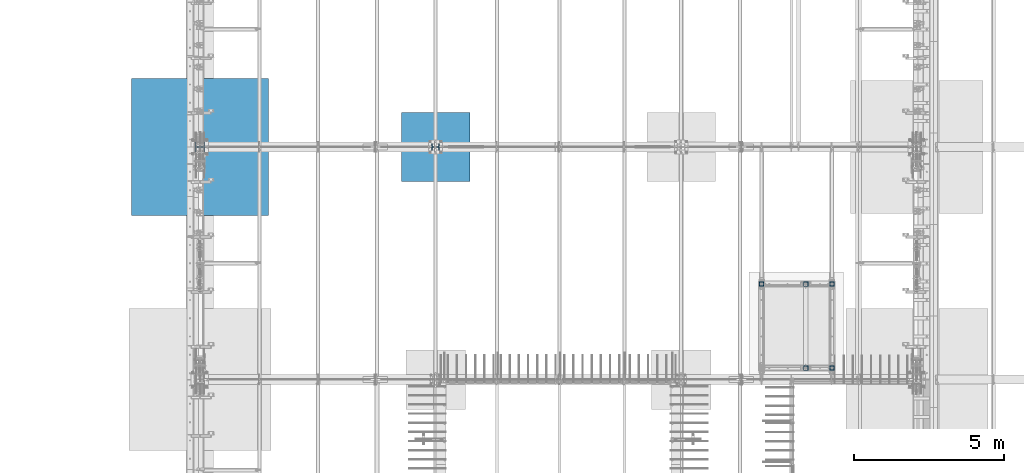
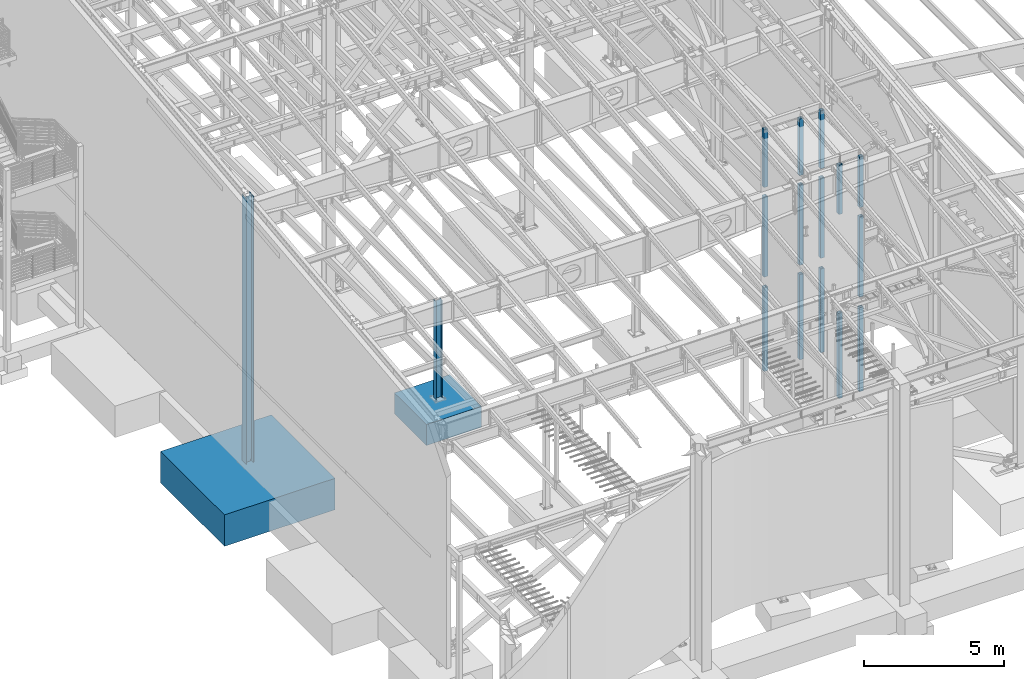
# One storey, part 356 of 1179: 18 columns, 18 elements without a shape of their own.
"""IFC2X3 building model written with IfcOpenShell, lengths in millimetres."""

from ifc_helpers import new_model, si_unit, frame, origin_with_axes, place, context, subcontext, project, spatial, faceted_brep, material, type_object, element, aggregate, save


model = new_model("IFC2X3")

# Units and contexts
model_context = context("Model", 3, precision=1e-05, world=origin_with_axes())
body_context = subcontext(model_context, "Body", "Model", "MODEL_VIEW")
ifc_project = project(units=[si_unit("LENGTHUNIT", "METRE", prefix="MILLI"), si_unit("AREAUNIT", "SQUARE_METRE"), si_unit("VOLUMEUNIT", "CUBIC_METRE"), si_unit("MASSUNIT", "GRAM", prefix="KILO"), si_unit("TIMEUNIT", "SECOND"), si_unit("PLANEANGLEUNIT", "RADIAN"), si_unit("SOLIDANGLEUNIT", "STERADIAN"), si_unit("THERMODYNAMICTEMPERATUREUNIT", "DEGREE_CELSIUS"), si_unit("LUMINOUSINTENSITYUNIT", "LUMEN")], contexts=[model_context])

# Site, building, storey
site_placement = place(None, origin_with_axes())
site = spatial("IfcSite", under=ifc_project, at=site_placement, CompositionType="ELEMENT")
building_placement = place(site_placement, origin_with_axes())
building = spatial("IfcBuilding", under=site, at=building_placement, Name="Undefined", CompositionType="ELEMENT")
storey_placement = place(building_placement, origin_with_axes())
storey = spatial("IfcBuildingStorey", under=building, at=storey_placement, Name="Undefined", CompositionType="ELEMENT", Elevation=0.0)

# Assembly, column
assembly_1_placement = place(storey_placement, origin_with_axes())
assembly_1 = element("IfcElementAssembly", 1, at=assembly_1_placement, inside=storey, Name="COLUMN", AssemblyPlace="NOTDEFINED", PredefinedType="RIGID_FRAME")
ifc_material_1 = material()
column_type_1 = type_object("IfcColumnType", Name="HSS6X6X3/8", PredefinedType="NOTDEFINED")
column_1_placement = place(assembly_1_placement, frame((21475.7, 11868.15, 4102.1), z_axis=(0.0, 1.0, 0.0), x_axis=(0.0, 0.0, 1.0)))
column_1 = element("IfcColumn", 2, at=column_1_placement, type_object=column_type_1, material=ifc_material_1, Name="COLUMN", ObjectType="HSS6X6X3/8", context=body_context, shape_type="Brep", body=[
    faceted_brep([(19.0500000000002, 66.6749999999993, -66.6749999999993), (19.0500000000002, -66.6749999999993, -66.6749999999993), (3524.25, -66.6749999999993, -66.6749999999993), (3524.25, 66.6749999999993, -66.6749999999993), (19.0500000000002, -66.6749999999993, 66.6749999999993), (3524.25, -66.6749999999993, 66.6749999999993), (19.0500000000002, 66.6749999999993, 66.6749999999993), (3524.25, 66.6749999999993, 66.6749999999993), (19.0500000000002, 76.2000000000007, -76.2000000000007), (19.0500000000002, 76.2000000000007, 76.2000000000007), (3524.25, 76.2000000000007, 76.2000000000007), (3524.25, 76.2000000000007, -76.2000000000007), (19.0500000000002, -76.2000000000007, 76.2000000000007), (3524.25, -76.2000000000007, 76.2000000000007), (19.0500000000002, -76.2000000000007, -76.2000000000007), (3524.25, -76.2000000000007, -76.2000000000007)], [[[0, 1, 2, 3]], [[1, 4, 5, 2]], [[4, 6, 7, 5]], [[6, 0, 3, 7]], [[8, 9, 10, 11]], [[9, 12, 13, 10]], [[12, 14, 15, 13]], [[14, 8, 11, 15]], [[13, 15, 11, 10], [5, 7, 3, 2]], [[14, 12, 9, 8], [6, 4, 1, 0]]]),
])
aggregate(assembly_1, [column_1])

assembly_2_placement = place(storey_placement, origin_with_axes())
assembly_2 = element("IfcElementAssembly", 3, at=assembly_2_placement, inside=storey, Name="COLUMN", AssemblyPlace="NOTDEFINED", PredefinedType="RIGID_FRAME")
column_2_placement = place(assembly_2_placement, frame((19138.9, 14662.15, 4102.1), z_axis=(0.0, 1.0, 0.0), x_axis=(0.0, 0.0, 1.0)))
column_2 = element("IfcColumn", 4, at=column_2_placement, type_object=column_type_1, material=ifc_material_1, Name="COLUMN", ObjectType="HSS6X6X3/8", context=body_context, shape_type="Brep", body=[
    faceted_brep([(19.0500000000002, 66.6749999999993, -66.6749999999993), (19.0500000000002, -66.6749999999993, -66.6749999999993), (3524.25, -66.6749999999993, -66.6749999999993), (3524.25, 66.6749999999993, -66.6749999999993), (19.0500000000002, -66.6749999999993, 66.6749999999993), (3524.25, -66.6749999999993, 66.6749999999993), (19.0500000000002, 66.6749999999993, 66.6749999999993), (3524.25, 66.6749999999993, 66.6749999999993), (19.0500000000002, 76.2000000000007, -76.2000000000007), (19.0500000000002, 76.2000000000007, 76.2000000000007), (3524.25, 76.2000000000007, 76.2000000000007), (3524.25, 76.2000000000007, -76.2000000000007), (19.0500000000002, -76.2000000000007, 76.2000000000007), (3524.25, -76.2000000000007, 76.2000000000007), (19.0500000000002, -76.2000000000007, -76.2000000000007), (3524.25, -76.2000000000007, -76.2000000000007)], [[[0, 1, 2, 3]], [[1, 4, 5, 2]], [[4, 6, 7, 5]], [[6, 0, 3, 7]], [[8, 9, 10, 11]], [[9, 12, 13, 10]], [[12, 14, 15, 13]], [[14, 8, 11, 15]], [[13, 15, 11, 10], [5, 7, 3, 2]], [[14, 12, 9, 8], [6, 4, 1, 0]]]),
])
aggregate(assembly_2, [column_2])

assembly_3_placement = place(storey_placement, origin_with_axes())
assembly_3 = element("IfcElementAssembly", 5, at=assembly_3_placement, inside=storey, Name="COLUMN", AssemblyPlace="NOTDEFINED", PredefinedType="RIGID_FRAME")
column_3_placement = place(assembly_3_placement, frame((21475.7, 14662.15, 4102.1), z_axis=(0.0, 1.0, 0.0), x_axis=(0.0, 0.0, 1.0)))
column_3 = element("IfcColumn", 6, at=column_3_placement, type_object=column_type_1, material=ifc_material_1, Name="COLUMN", ObjectType="HSS6X6X3/8", context=body_context, shape_type="Brep", body=[
    faceted_brep([(19.0500000000002, 66.6749999999993, -66.6749999999993), (19.0500000000002, -66.6749999999993, -66.6749999999993), (3524.25, -66.6749999999993, -66.6749999999993), (3524.25, 66.6749999999993, -66.6749999999993), (19.0500000000002, -66.6749999999993, 66.6749999999993), (3524.25, -66.6749999999993, 66.6749999999993), (19.0500000000002, 66.6749999999993, 66.6749999999993), (3524.25, 66.6749999999993, 66.6749999999993), (19.0500000000002, 76.2000000000007, -76.2000000000007), (19.0500000000002, 76.2000000000007, 76.2000000000007), (3524.25, 76.2000000000007, 76.2000000000007), (3524.25, 76.2000000000007, -76.2000000000007), (19.0500000000002, -76.2000000000007, 76.2000000000007), (3524.25, -76.2000000000007, 76.2000000000007), (19.0500000000002, -76.2000000000007, -76.2000000000007), (3524.25, -76.2000000000007, -76.2000000000007)], [[[0, 1, 2, 3]], [[1, 4, 5, 2]], [[4, 6, 7, 5]], [[6, 0, 3, 7]], [[8, 9, 10, 11]], [[9, 12, 13, 10]], [[12, 14, 15, 13]], [[14, 8, 11, 15]], [[13, 15, 11, 10], [5, 7, 3, 2]], [[14, 12, 9, 8], [6, 4, 1, 0]]]),
])
aggregate(assembly_3, [column_3])

assembly_4_placement = place(storey_placement, origin_with_axes())
assembly_4 = element("IfcElementAssembly", 7, at=assembly_4_placement, inside=storey, Name="COLUMN", AssemblyPlace="NOTDEFINED", PredefinedType="RIGID_FRAME")
column_4_placement = place(assembly_4_placement, frame((20612.1, 14662.15, 4102.1), z_axis=(0.0, 1.0, 0.0), x_axis=(0.0, 0.0, 1.0)))
column_4 = element("IfcColumn", 8, at=column_4_placement, type_object=column_type_1, material=ifc_material_1, Name="COLUMN", ObjectType="HSS6X6X3/8", context=body_context, shape_type="Brep", body=[
    faceted_brep([(19.0500000000002, 66.6749999999993, -66.6749999999993), (19.0500000000002, -66.6749999999993, -66.6749999999993), (3524.25, -66.6749999999993, -66.6749999999993), (3524.25, 66.6749999999993, -66.6749999999993), (19.0500000000002, -66.6749999999993, 66.6749999999993), (3524.25, -66.6749999999993, 66.6749999999993), (19.0500000000002, 66.6749999999993, 66.6749999999993), (3524.25, 66.6749999999993, 66.6749999999993), (19.0500000000002, 76.2000000000007, -76.2000000000007), (19.0500000000002, 76.2000000000007, 76.2000000000007), (3524.25, 76.2000000000007, 76.2000000000007), (3524.25, 76.2000000000007, -76.2000000000007), (19.0500000000002, -76.2000000000007, 76.2000000000007), (3524.25, -76.2000000000007, 76.2000000000007), (19.0500000000002, -76.2000000000007, -76.2000000000007), (3524.25, -76.2000000000007, -76.2000000000007)], [[[0, 1, 2, 3]], [[1, 4, 5, 2]], [[4, 6, 7, 5]], [[6, 0, 3, 7]], [[8, 9, 10, 11]], [[9, 12, 13, 10]], [[12, 14, 15, 13]], [[14, 8, 11, 15]], [[13, 15, 11, 10], [5, 7, 3, 2]], [[14, 12, 9, 8], [6, 4, 1, 0]]]),
])
aggregate(assembly_4, [column_4])

assembly_5_placement = place(storey_placement, origin_with_axes())
assembly_5 = element("IfcElementAssembly", 9, at=assembly_5_placement, inside=storey, Name="COLUMN", AssemblyPlace="NOTDEFINED", PredefinedType="RIGID_FRAME")
column_5_placement = place(assembly_5_placement, frame((21475.7, 11868.15, 8013.7), z_axis=(0.0, 1.0, 0.0), x_axis=(0.0, 0.0, 1.0)))
column_5 = element("IfcColumn", 10, at=column_5_placement, type_object=column_type_1, material=ifc_material_1, Name="COLUMN", ObjectType="HSS6X6X3/8", context=body_context, shape_type="Brep", body=[
    faceted_brep([(19.0500000000002, 66.6749999999993, -66.6749999999993), (19.0500000000002, -66.6749999999993, -66.6749999999993), (2231.40740840967, -66.6749999999993, -66.6749999999993), (2231.40740840967, 66.6749999999993, -66.6749999999993), (19.0500000000002, -66.6749999999993, 66.6749999999993), (2231.40740840967, -66.6749999999993, 66.6749999999993), (19.0500000000002, 66.6749999999993, 66.6749999999993), (2231.40740840967, 66.6749999999993, 66.6749999999993), (19.0500000000002, 76.2000000000007, -76.2000000000007), (19.0500000000002, 76.2000000000007, 76.2000000000007), (2231.40740840967, 76.2000000000007, 76.2000000000007), (2231.40740840967, 76.2000000000007, -76.2000000000007), (19.0500000000002, -76.2000000000007, 76.2000000000007), (2231.40740840967, -76.2000000000007, 76.2000000000007), (19.0500000000002, -76.2000000000007, -76.2000000000007), (2231.40740840967, -76.2000000000007, -76.2000000000007)], [[[0, 1, 2, 3]], [[1, 4, 5, 2]], [[4, 6, 7, 5]], [[6, 0, 3, 7]], [[8, 9, 10, 11]], [[9, 12, 13, 10]], [[12, 14, 15, 13]], [[14, 8, 11, 15]], [[13, 15, 11, 10], [5, 7, 3, 2]], [[14, 12, 9, 8], [6, 4, 1, 0]]]),
])
aggregate(assembly_5, [column_5])

assembly_6_placement = place(storey_placement, origin_with_axes())
assembly_6 = element("IfcElementAssembly", 11, at=assembly_6_placement, inside=storey, Name="COLUMN", AssemblyPlace="NOTDEFINED", PredefinedType="RIGID_FRAME")
column_6_placement = place(assembly_6_placement, frame((20612.1, 11868.15, 8013.7), z_axis=(0.0, 1.0, 0.0), x_axis=(0.0, 0.0, 1.0)))
column_6 = element("IfcColumn", 12, at=column_6_placement, type_object=column_type_1, material=ifc_material_1, Name="COLUMN", ObjectType="HSS6X6X3/8", context=body_context, shape_type="Brep", body=[
    faceted_brep([(19.0500000000002, 66.6749999999993, -66.6749999999993), (19.0500000000002, -66.6749999999993, -66.6749999999993), (2179.835937, -66.6749999999993, -66.6749999999993), (2179.835937, 66.6749999999993, -66.6749999999993), (19.0500000000002, -66.6749999999993, 66.6749999999993), (2179.835937, -66.6749999999993, 66.6749999999993), (19.0500000000002, 66.6749999999993, 66.6749999999993), (2179.835937, 66.6749999999993, 66.6749999999993), (19.0500000000002, 76.2000000000007, -76.2000000000007), (19.0500000000002, 76.2000000000007, 76.2000000000007), (2179.835937, 76.2000000000007, 76.2000000000007), (2179.835937, 76.2000000000007, -76.2000000000007), (19.0500000000002, -76.2000000000007, 76.2000000000007), (2179.835937, -76.2000000000007, 76.2000000000007), (19.0500000000002, -76.2000000000007, -76.2000000000007), (2179.835937, -76.2000000000007, -76.2000000000007)], [[[0, 1, 2, 3]], [[1, 4, 5, 2]], [[4, 6, 7, 5]], [[6, 0, 3, 7]], [[8, 9, 10, 11]], [[9, 12, 13, 10]], [[12, 14, 15, 13]], [[14, 8, 11, 15]], [[13, 15, 11, 10], [5, 7, 3, 2]], [[14, 12, 9, 8], [6, 4, 1, 0]]]),
])
aggregate(assembly_6, [column_6])

assembly_7_placement = place(storey_placement, origin_with_axes())
assembly_7 = element("IfcElementAssembly", 13, at=assembly_7_placement, inside=storey, Name="COLUMN", AssemblyPlace="NOTDEFINED", PredefinedType="RIGID_FRAME")
column_7_placement = place(assembly_7_placement, frame((21475.7, 14662.15, 8013.7), z_axis=(0.0, 1.0, 0.0), x_axis=(0.0, 0.0, 1.0)))
column_7 = element("IfcColumn", 14, at=column_7_placement, type_object=column_type_1, material=ifc_material_1, Name="COLUMN", ObjectType="HSS6X6X3/8", context=body_context, shape_type="Brep", body=[
    faceted_brep([(19.0500000000002, 66.6749999999993, -66.6749999999993), (19.0500000000002, -66.6749999999993, -66.6749999999993), (2547.12147140967, -66.6749999999993, -66.6749999999993), (2547.12147140967, 66.6749999999993, -66.6749999999993), (19.0500000000002, -66.6749999999993, 66.6749999999993), (2547.12147140967, -66.6749999999993, 66.6749999999993), (19.0500000000002, 66.6749999999993, 66.6749999999993), (2547.12147140967, 66.6749999999993, 66.6749999999993), (19.0500000000002, 76.2000000000007, -76.2000000000007), (19.0500000000002, 76.2000000000007, 76.2000000000007), (2547.12147140967, 76.2000000000007, 76.2000000000007), (2547.12147140967, 76.2000000000007, -76.2000000000007), (19.0500000000002, -76.2000000000007, 76.2000000000007), (2547.12147140967, -76.2000000000007, 76.2000000000007), (19.0500000000002, -76.2000000000007, -76.2000000000007), (2547.12147140967, -76.2000000000007, -76.2000000000007)], [[[0, 1, 2, 3]], [[1, 4, 5, 2]], [[4, 6, 7, 5]], [[6, 0, 3, 7]], [[8, 9, 10, 11]], [[9, 12, 13, 10]], [[12, 14, 15, 13]], [[14, 8, 11, 15]], [[13, 15, 11, 10], [5, 7, 3, 2]], [[14, 12, 9, 8], [6, 4, 1, 0]]]),
])
aggregate(assembly_7, [column_7])

assembly_8_placement = place(storey_placement, origin_with_axes())
assembly_8 = element("IfcElementAssembly", 15, at=assembly_8_placement, inside=storey, Name="COLUMN", AssemblyPlace="NOTDEFINED", PredefinedType="RIGID_FRAME")
column_8_placement = place(assembly_8_placement, frame((20612.1, 14662.15, 8013.7), z_axis=(0.0, 1.0, 0.0), x_axis=(0.0, 0.0, 1.0)))
column_8 = element("IfcColumn", 16, at=column_8_placement, type_object=column_type_1, material=ifc_material_1, Name="COLUMN", ObjectType="HSS6X6X3/8", context=body_context, shape_type="Brep", body=[
    faceted_brep([(19.0500000000002, 66.6749999999993, -66.6749999999993), (19.0500000000002, -66.6749999999993, -66.6749999999993), (2495.45821831457, -66.6749999999993, -66.6749999999993), (2495.45821831457, 66.6749999999993, -66.6749999999993), (19.0500000000002, -66.6749999999993, 66.6749999999993), (2495.45821831457, -66.6749999999993, 66.6749999999993), (19.0500000000002, 66.6749999999993, 66.6749999999993), (2495.45821831457, 66.6749999999993, 66.6749999999993), (19.0500000000002, 76.2000000000007, -76.2000000000007), (19.0500000000002, 76.2000000000007, 76.2000000000007), (2495.45821831457, 76.2000000000007, 76.2000000000007), (2495.45821831457, 76.2000000000007, -76.2000000000007), (19.0500000000002, -76.2000000000007, 76.2000000000007), (2495.45821831457, -76.2000000000007, 76.2000000000007), (19.0500000000002, -76.2000000000007, -76.2000000000007), (2495.45821831457, -76.2000000000007, -76.2000000000007)], [[[0, 1, 2, 3]], [[1, 4, 5, 2]], [[4, 6, 7, 5]], [[6, 0, 3, 7]], [[8, 9, 10, 11]], [[9, 12, 13, 10]], [[12, 14, 15, 13]], [[14, 8, 11, 15]], [[13, 15, 11, 10], [5, 7, 3, 2]], [[14, 12, 9, 8], [6, 4, 1, 0]]]),
])
aggregate(assembly_8, [column_8])

assembly_9_placement = place(storey_placement, origin_with_axes())
assembly_9 = element("IfcElementAssembly", 17, at=assembly_9_placement, inside=storey, Name="COLUMN", AssemblyPlace="NOTDEFINED", PredefinedType="RIGID_FRAME")
column_9_placement = place(assembly_9_placement, frame((19138.9, 14662.15, 8013.7), z_axis=(0.0, 1.0, 0.0), x_axis=(0.0, 0.0, 1.0)))
column_9 = element("IfcColumn", 18, at=column_9_placement, type_object=column_type_1, material=ifc_material_1, Name="COLUMN", ObjectType="HSS6X6X3/8", context=body_context, shape_type="Brep", body=[
    faceted_brep([(19.0500000000002, 66.6749999999993, -66.6749999999993), (19.0500000000002, -66.6749999999993, -66.6749999999993), (2547.12147140967, -66.6749999999993, -66.6749999999993), (2547.12147140967, 66.6749999999993, -66.6749999999993), (19.0500000000002, -66.6749999999993, 66.6749999999993), (2547.12147140967, -66.6749999999993, 66.6749999999993), (19.0500000000002, 66.6749999999993, 66.6749999999993), (2547.12147140967, 66.6749999999993, 66.6749999999993), (19.0500000000002, 76.2000000000007, -76.2000000000007), (19.0500000000002, 76.2000000000007, 76.2000000000007), (2547.12147140967, 76.2000000000007, 76.2000000000007), (2547.12147140967, 76.2000000000007, -76.2000000000007), (19.0500000000002, -76.2000000000007, 76.2000000000007), (2547.12147140967, -76.2000000000007, 76.2000000000007), (19.0500000000002, -76.2000000000007, -76.2000000000007), (2547.12147140967, -76.2000000000007, -76.2000000000007)], [[[0, 1, 2, 3]], [[1, 4, 5, 2]], [[4, 6, 7, 5]], [[6, 0, 3, 7]], [[8, 9, 10, 11]], [[9, 12, 13, 10]], [[12, 14, 15, 13]], [[14, 8, 11, 15]], [[13, 15, 11, 10], [5, 7, 3, 2]], [[14, 12, 9, 8], [6, 4, 1, 0]]]),
])
aggregate(assembly_9, [column_9])

assembly_10_placement = place(storey_placement, origin_with_axes())
assembly_10 = element("IfcElementAssembly", 19, at=assembly_10_placement, inside=storey, Name="COLUMN", AssemblyPlace="NOTDEFINED", PredefinedType="RIGID_FRAME")
column_10_placement = place(assembly_10_placement, frame((20612.1, 14662.15, 0.0), z_axis=(0.0, 1.0, 0.0), x_axis=(0.0, 0.0, 1.0)))
column_10 = element("IfcColumn", 20, at=column_10_placement, type_object=column_type_1, material=ifc_material_1, Name="COLUMN", ObjectType="HSS6X6X3/8", context=body_context, shape_type="Brep", body=[
    faceted_brep([(0.0, 66.6749999999993, -66.6750000000029), (0.0, -66.6749999999993, -66.6750000000029), (3714.75000000008, -66.6749999999993, -66.6749999999993), (3714.75000000008, 66.6749999999993, -66.6749999999993), (0.0, -66.6749999999993, 66.6750000000029), (3714.75000000008, -66.6749999999993, 66.6749999999993), (0.0, 66.6749999999993, 66.6750000000029), (3714.75000000008, 66.6749999999993, 66.6749999999993), (6.54836185276508e-11, 76.2, -76.1999999999998), (6.54836185276508e-11, 76.2, 76.1999999999998), (3714.75000000008, 76.2000000000007, 76.2000000000007), (3714.75000000008, 76.2000000000007, -76.2000000000007), (-6.54836185276508e-11, -76.2, 76.1999999999998), (3714.75000000008, -76.2000000000007, 76.2000000000007), (-6.54836185276508e-11, -76.2, -76.1999999999998), (3714.75000000008, -76.2000000000007, -76.2000000000007)], [[[0, 1, 2, 3]], [[1, 4, 5, 2]], [[4, 6, 7, 5]], [[6, 0, 3, 7]], [[8, 9, 10, 11]], [[9, 12, 13, 10]], [[12, 14, 15, 13]], [[14, 8, 11, 15]], [[13, 15, 11, 10], [5, 7, 3, 2]], [[14, 12, 9, 8], [6, 4, 1, 0]]]),
])
aggregate(assembly_10, [column_10])

assembly_11_placement = place(storey_placement, origin_with_axes())
assembly_11 = element("IfcElementAssembly", 21, at=assembly_11_placement, inside=storey, Name="COLUMN", AssemblyPlace="NOTDEFINED", PredefinedType="RIGID_FRAME")
column_11_placement = place(assembly_11_placement, frame((20612.1, 11868.15, 0.0), z_axis=(0.0, 1.0, 0.0), x_axis=(0.0, 0.0, 1.0)))
column_11 = element("IfcColumn", 22, at=column_11_placement, type_object=column_type_1, material=ifc_material_1, Name="COLUMN", ObjectType="HSS6X6X3/8", context=body_context, shape_type="Brep", body=[
    faceted_brep([(0.0, 66.6749999999993, -66.6750000000029), (0.0, -66.6749999999993, -66.6750000000029), (3714.75000000008, -66.6749999999993, -66.6749999999993), (3714.75000000008, 66.6749999999993, -66.6749999999993), (0.0, -66.6749999999993, 66.6750000000029), (3714.75000000008, -66.6749999999993, 66.6749999999993), (0.0, 66.6749999999993, 66.6750000000029), (3714.75000000008, 66.6749999999993, 66.6749999999993), (6.54836185276508e-11, 76.2, -76.1999999999998), (6.54836185276508e-11, 76.2, 76.1999999999998), (3714.75000000008, 76.2000000000007, 76.2000000000007), (3714.75000000008, 76.2000000000007, -76.2000000000007), (-6.54836185276508e-11, -76.2, 76.1999999999998), (3714.75000000008, -76.2000000000007, 76.2000000000007), (-6.54836185276508e-11, -76.2, -76.1999999999998), (3714.75000000008, -76.2000000000007, -76.2000000000007)], [[[0, 1, 2, 3]], [[1, 4, 5, 2]], [[4, 6, 7, 5]], [[6, 0, 3, 7]], [[8, 9, 10, 11]], [[9, 12, 13, 10]], [[12, 14, 15, 13]], [[14, 8, 11, 15]], [[13, 15, 11, 10], [5, 7, 3, 2]], [[14, 12, 9, 8], [6, 4, 1, 0]]]),
])
aggregate(assembly_11, [column_11])

assembly_12_placement = place(storey_placement, origin_with_axes())
assembly_12 = element("IfcElementAssembly", 23, at=assembly_12_placement, inside=storey, Name="COLUMN", AssemblyPlace="NOTDEFINED", PredefinedType="RIGID_FRAME")
column_type_2 = type_object("IfcColumnType", Name="HSS6X6X5/8", PredefinedType="NOTDEFINED")
column_12_placement = place(assembly_12_placement, frame((19138.8967731331, 14662.1500000111, -4.59294824395329e-11), z_axis=(0.0, 1.0, 0.0), x_axis=(0.0, 0.0, 1.0)))
column_12 = element("IfcColumn", 24, at=column_12_placement, type_object=column_type_2, material=ifc_material_1, Name="COLUMN", ObjectType="HSS6X6X5/8", context=body_context, shape_type="Brep", body=[
    faceted_brep([(0.0, 60.3250000000007, -60.3250000000007), (2.71050543121376e-20, -60.3250000000007, -60.3250000000007), (3660.775, -60.325000001314, -60.3250000000007), (3660.775, 60.3249999986838, -60.3250000000007), (2.71050543121376e-20, -60.3250000000007, 60.3250000000007), (3660.775, -60.325000001314, 60.3250000000007), (0.0, 60.3250000000007, 60.3250000000007), (3660.775, 60.3249999986838, 60.3250000000007), (6.54836185276508e-11, 76.2, -76.1999999999998), (6.54836185276508e-11, 76.2, 76.1999999999998), (3660.775, 76.1999999986838, 76.2000000000007), (3660.775, 76.1999999986838, -76.2000000000007), (-6.54836185276508e-11, -76.2, 76.1999999999998), (3660.775, -76.200000001314, 76.2000000000007), (-6.54836185276508e-11, -76.2, -76.1999999999998), (3660.775, -76.200000001314, -76.2000000000007)], [[[0, 1, 2, 3]], [[1, 4, 5, 2]], [[4, 6, 7, 5]], [[6, 0, 3, 7]], [[8, 9, 10, 11]], [[9, 12, 13, 10]], [[12, 14, 15, 13]], [[14, 8, 11, 15]], [[13, 15, 11, 10], [5, 7, 3, 2]], [[14, 12, 9, 8], [6, 4, 1, 0]]]),
])
aggregate(assembly_12, [column_12])

assembly_13_placement = place(storey_placement, origin_with_axes())
assembly_13 = element("IfcElementAssembly", 25, at=assembly_13_placement, inside=storey, Name="COLUMN", AssemblyPlace="NOTDEFINED", PredefinedType="RIGID_FRAME")
column_13_placement = place(assembly_13_placement, frame((21475.7, 14662.15, 0.0), z_axis=(0.0, 1.0, 0.0), x_axis=(0.0, 0.0, 1.0)))
column_13 = element("IfcColumn", 26, at=column_13_placement, type_object=column_type_2, material=ifc_material_1, Name="COLUMN", ObjectType="HSS6X6X5/8", context=body_context, shape_type="Brep", body=[
    faceted_brep([(0.0, 60.3250000000007, -60.3250000000007), (2.71050543121376e-20, -60.3250000000007, -60.3250000000007), (3660.775, -60.325000001314, -60.3250000000007), (3660.775, 60.3249999986838, -60.3250000000007), (2.71050543121376e-20, -60.3250000000007, 60.3250000000007), (3660.775, -60.325000001314, 60.3250000000007), (0.0, 60.3250000000007, 60.3250000000007), (3660.775, 60.3249999986838, 60.3250000000007), (6.54836185276508e-11, 76.2, -76.1999999999998), (6.54836185276508e-11, 76.2, 76.1999999999998), (3660.775, 76.1999999986838, 76.2000000000007), (3660.775, 76.1999999986838, -76.2000000000007), (-6.54836185276508e-11, -76.2, 76.1999999999998), (3660.775, -76.200000001314, 76.2000000000007), (-6.54836185276508e-11, -76.2, -76.1999999999998), (3660.775, -76.200000001314, -76.2000000000007)], [[[0, 1, 2, 3]], [[1, 4, 5, 2]], [[4, 6, 7, 5]], [[6, 0, 3, 7]], [[8, 9, 10, 11]], [[9, 12, 13, 10]], [[12, 14, 15, 13]], [[14, 8, 11, 15]], [[13, 15, 11, 10], [5, 7, 3, 2]], [[14, 12, 9, 8], [6, 4, 1, 0]]]),
])
aggregate(assembly_13, [column_13])

assembly_14_placement = place(storey_placement, origin_with_axes())
assembly_14 = element("IfcElementAssembly", 27, at=assembly_14_placement, inside=storey, Name="COLUMN", AssemblyPlace="NOTDEFINED", PredefinedType="RIGID_FRAME")
column_14_placement = place(assembly_14_placement, frame((21475.7, 11868.15, 0.0), z_axis=(0.0, 1.0, 0.0), x_axis=(0.0, 0.0, 1.0)))
column_14 = element("IfcColumn", 28, at=column_14_placement, type_object=column_type_2, material=ifc_material_1, Name="COLUMN", ObjectType="HSS6X6X5/8", context=body_context, shape_type="Brep", body=[
    faceted_brep([(0.0, 60.3250000000007, -60.3250000000007), (2.71050543121376e-20, -60.3250000000007, -60.3250000000007), (3660.775, -60.325000001314, -60.3250000000007), (3660.775, 60.3249999986838, -60.3250000000007), (2.71050543121376e-20, -60.3250000000007, 60.3250000000007), (3660.775, -60.325000001314, 60.3250000000007), (0.0, 60.3250000000007, 60.3250000000007), (3660.775, 60.3249999986838, 60.3250000000007), (6.54836185276508e-11, 76.2, -76.1999999999998), (6.54836185276508e-11, 76.2, 76.1999999999998), (3660.775, 76.1999999986838, 76.2000000000007), (3660.775, 76.1999999986838, -76.2000000000007), (-6.54836185276508e-11, -76.2, 76.1999999999998), (3660.775, -76.200000001314, 76.2000000000007), (-6.54836185276508e-11, -76.2, -76.1999999999998), (3660.775, -76.200000001314, -76.2000000000007)], [[[0, 1, 2, 3]], [[1, 4, 5, 2]], [[4, 6, 7, 5]], [[6, 0, 3, 7]], [[8, 9, 10, 11]], [[9, 12, 13, 10]], [[12, 14, 15, 13]], [[14, 8, 11, 15]], [[13, 15, 11, 10], [5, 7, 3, 2]], [[14, 12, 9, 8], [6, 4, 1, 0]]]),
])
aggregate(assembly_14, [column_14])

assembly_15_placement = place(storey_placement, origin_with_axes())
assembly_15 = element("IfcElementAssembly", 29, at=assembly_15_placement, inside=storey, Name="FOOTING", AssemblyPlace="NOTDEFINED", PredefinedType="REINFORCEMENT_UNIT")
ifc_material_2 = material(Name="CONCRETE/3000")
column_type_3 = type_object("IfcColumnType", PredefinedType="NOTDEFINED")
column_15_placement = place(assembly_15_placement, frame((8280.4, 19227.8, -1168.4), z_axis=(-1.0, 0.0, 0.0), x_axis=(0.0, 0.0, 1.0)))
column_15 = element("IfcColumn", 30, at=column_15_placement, type_object=column_type_3, material=ifc_material_2, Name="FOOTING", context=body_context, shape_type="Brep", body=[
    faceted_brep([(0.0, 1143.0, -1143.0), (0.0, 1143.0, 1143.0), (914.4, 1143.0, 1143.0), (914.4, 1143.0, -1143.0), (0.0, -1143.0, 1143.0), (914.4, -1143.0, 1143.0), (0.0, -1143.0, -1143.0), (914.4, -1143.0, -1143.0)], [[[0, 1, 2, 3]], [[1, 4, 5, 2]], [[4, 6, 7, 5]], [[6, 0, 3, 7]], [[5, 7, 3, 2]], [[6, 4, 1, 0]]]),
])
aggregate(assembly_15, [column_15])

assembly_16_placement = place(storey_placement, origin_with_axes())
assembly_16 = element("IfcElementAssembly", 31, at=assembly_16_placement, inside=storey, Name="FOOTING", AssemblyPlace="NOTDEFINED", PredefinedType="REINFORCEMENT_UNIT")
column_type_4 = type_object("IfcColumnType", PredefinedType="NOTDEFINED")
column_16_placement = place(assembly_16_placement, frame((431.800000000002, 19227.8, -1727.2), z_axis=(-1.0, 0.0, 0.0), x_axis=(0.0, 0.0, 1.0)))
column_16 = element("IfcColumn", 32, at=column_16_placement, type_object=column_type_4, material=ifc_material_2, Name="FOOTING", context=body_context, shape_type="Brep", body=[
    faceted_brep([(0.0, 2286.0, -2286.0), (0.0, 2286.0, 2286.0), (1371.6, 2286.0, 2286.0), (1371.6, 2286.0, -2286.0), (0.0, -2286.0, 2286.0), (1371.6, -2286.0, 2286.0), (0.0, -2286.0, -2286.0), (1371.6, -2286.0, -2286.0)], [[[0, 1, 2, 3]], [[1, 4, 5, 2]], [[4, 6, 7, 5]], [[6, 0, 3, 7]], [[5, 7, 3, 2]], [[6, 4, 1, 0]]]),
])
aggregate(assembly_16, [column_16])

assembly_17_placement = place(storey_placement, origin_with_axes())
assembly_17 = element("IfcElementAssembly", 33, at=assembly_17_placement, inside=storey, Name="COLUMN", AssemblyPlace="NOTDEFINED", PredefinedType="RIGID_FRAME")
ifc_material_3 = material(Name="STEEL/A992")
column_type_5 = type_object("IfcColumnType", Name="W12X79", PredefinedType="NOTDEFINED")
column_17_placement = place(assembly_17_placement, frame((431.800000000002, 19227.8, -355.6), z_axis=(-1.0, 0.0, 0.0), x_axis=(0.0, 0.0, 1.0)))
column_17 = element("IfcColumn", 34, at=column_17_placement, type_object=column_type_5, material=ifc_material_3, Name="COLUMN", ObjectType="W12X79", context=body_context, shape_type="Brep", body=[
    faceted_brep([(160.223581529497, -153.987499999999, 157.1625), (160.223581529497, 153.987499999999, 157.1625), (149.225002356772, 153.987499999999, 138.1125), (149.225002356772, 6.35000012494493, 138.1125), (148.995793121516, 6.35000012313685, 137.715499999996), (148.995793121516, -6.34999999999854, 137.715499999996), (149.225002356772, -6.34999999999854, 138.1125), (149.225002356772, -153.987499999999, 138.1125), (188.913, -6.34999999999854, 137.715499999996), (188.913, 6.35000008947463, 137.715499999996), (208.49066058208, 6.35000008789211, 131.2871410688), (208.49066058208, -6.34999999999854, 131.2871410688), (212.873373738864, 6.35000008718271, 128.290736246858), (212.873373738864, -6.34999999999854, 128.290736246858), (214.971292158606, 6.35000008606585, 123.413713099926), (214.971292158606, -6.34999999999854, 123.413713099926), (214.132634973196, 6.3500000848835, 118.171264187733), (214.132634973196, -6.34999999999854, 118.171264187733), (210.617956026487, 6.35000008400311, 114.192112472459), (210.617956026487, -6.34999999999854, 114.192112472459), (205.519195059062, 6.35000008370116, 112.712499999996), (205.519195059062, -6.34999999999854, 112.712499999996), (147.032344061553, 6.35000011347802, 112.712499999996), (139.700000000001, -6.34999999999854, 112.712499999996), (147.032344061555, 6.35000001149092, -112.712500000003), (139.700000000001, -6.34999999999854, -112.712500000003), (205.519195059063, 6.3500000365857, -112.712500000003), (205.519195059063, -6.34999999999854, -112.712500000003), (210.617956026486, 6.35000003621826, -114.192112472468), (210.617956026486, -6.34999999999854, -114.192112472468), (214.132634973195, 6.35000003529422, -118.171264187741), (214.132634973195, -6.34999999999854, -118.171264187741), (214.971292158605, 6.35000003410096, -123.413713099934), (214.971292158605, -6.34999999999854, -123.413713099934), (212.873373738863, 6.35000003300956, -128.290736246865), (212.873373738863, -6.34999999999854, -128.290736246865), (208.49066058208, 6.35000003235837, -131.287141068808), (208.49066058208, -6.34999999999854, -131.287141068808), (188.913, 6.35000003102323, -137.715500000003), (188.913, -6.34999999999854, -137.715500000003), (148.99620123074, 6.35000000162472, -137.715500000003), (148.99620123074, -6.34999999999854, -137.715500000003), (11747.1544804954, 6.34999999999854, -138.1125), (11775.9344077457, 6.34999999999854, -138.1125), (11792.5357237654, 153.987499999999, -138.1125), (149.225402461476, 153.987499999999, -138.1125), (149.225402461477, 6.34999999999854, -138.1125), (11757.9050215307, -153.987499999999, -138.112499999999), (11757.9050215307, -153.987499999999, -157.162499999999), (11792.5357237654, 153.987499999999, -157.1625), (11774.5063375505, -6.34999999999854, -138.1125), (149.225402461476, -153.987499999999, -138.1125), (160.223597538519, -153.987499999999, -157.1625), (160.223597538519, 153.987499999999, -157.1625), (149.225402461476, -6.34999999999854, -138.1125), (11745.7193973341, -6.34999999999854, -138.1125), (11747.1544804954, 6.35000000020227, 138.1125), (11745.7193973341, -6.34999999999854, 138.1125), (11775.8295637731, 6.35000000022046, 138.112500001068), (11774.5063375505, -6.34999999999854, 138.1125), (11792.5357237654, 153.987499999999, 138.1125), (11792.5357237654, 153.987499999999, 157.1625), (11757.9050215307, -153.987499999999, 157.162499999999), (11757.9050215307, -153.987499999999, 138.112499999999)], [[[0, 1, 2, 3, 4, 5, 6, 7]], [[8, 9, 10, 11]], [[11, 10, 12, 13]], [[13, 12, 14, 15]], [[15, 14, 16, 17]], [[17, 16, 18, 19]], [[19, 18, 20, 21]], [[21, 20, 22, 23]], [[24, 25, 23, 22]], [[25, 24, 26, 27]], [[27, 26, 28, 29]], [[29, 28, 30, 31]], [[31, 30, 32, 33]], [[33, 32, 34, 35]], [[35, 34, 36, 37]], [[37, 36, 38, 39]], [[39, 38, 40, 41]], [[42, 43, 44, 45, 46]], [[47, 48, 49, 44, 43, 50]], [[48, 47, 51, 52]], [[49, 48, 52, 53]], [[44, 49, 53, 45]], [[52, 51, 54, 41, 40, 46, 45, 53]], [[47, 50, 55, 54, 51]], [[43, 42, 55, 50]], [[56, 57, 55, 42]], [[58, 59, 57, 56]], [[60, 61, 62, 63, 59, 58]], [[63, 62, 0, 7]], [[57, 59, 63, 7, 6]], [[8, 11, 13, 15, 17, 19, 21, 23, 25, 27, 29, 31, 33, 35, 37, 39, 41, 54, 55, 57, 6, 5]], [[9, 8, 5, 4]], [[56, 42, 46, 40, 38, 36, 34, 32, 30, 28, 26, 24, 22, 20, 18, 16, 14, 12, 10, 9, 4, 3]], [[60, 58, 56, 3, 2]], [[61, 60, 2, 1]], [[62, 61, 1, 0]]]),
])
aggregate(assembly_17, [column_17])

assembly_18_placement = place(storey_placement, origin_with_axes())
assembly_18 = element("IfcElementAssembly", 35, at=assembly_18_placement, inside=storey, Name="COLUMN", AssemblyPlace="NOTDEFINED", PredefinedType="RIGID_FRAME")
column_type_6 = type_object("IfcColumnType", Name="W10X39", PredefinedType="NOTDEFINED")
column_18_placement = place(assembly_18_placement, frame((8280.4, 19227.8, -355.6), z_axis=(-1.0, 0.0, 0.0), x_axis=(0.0, 0.0, 1.0)))
column_18 = element("IfcColumn", 36, at=column_18_placement, type_object=column_type_6, material=ifc_material_3, Name="COLUMN", ObjectType="W10X39", context=body_context, shape_type="Brep", body=[
    faceted_brep([(190.5, 101.599999999999, -125.412499999999), (190.5, 101.599999999999, -112.712500000001), (4457.7, 101.599999999999, -112.712500000001), (4457.7, 101.599999999999, -125.412499999999), (190.5, 3.96875, -112.712500000001), (4457.7, 3.96875, -112.712500000001), (190.5, 3.96875, 112.7125), (4457.7, 3.96875, 112.7125), (190.5, 101.599999999999, 112.7125), (4457.7, 101.599999999999, 112.7125), (190.5, 101.599999999999, 125.4125), (4457.7, 101.599999999999, 125.4125), (190.5, -101.599999999999, 125.4125), (4457.7, -101.599999999999, 125.4125), (190.5, -101.599999999999, 112.7125), (4457.7, -101.599999999999, 112.7125), (190.5, -3.96875, 112.7125), (4457.7, -3.96875, 112.7125), (190.5, -3.96875, -112.712500000001), (4457.7, -3.96875, -112.712500000001), (190.5, -101.599999999999, -112.712500000001), (4457.7, -101.599999999999, -112.712500000001), (190.5, -101.599999999999, -125.412499999999), (4457.7, -101.599999999999, -125.412499999999)], [[[0, 1, 2, 3]], [[1, 4, 5, 2]], [[4, 6, 7, 5]], [[6, 8, 9, 7]], [[8, 10, 11, 9]], [[10, 12, 13, 11]], [[12, 14, 15, 13]], [[14, 16, 17, 15]], [[16, 18, 19, 17]], [[18, 20, 21, 19]], [[20, 22, 23, 21]], [[22, 0, 3, 23]], [[5, 7, 9, 11, 13, 15, 17, 19, 21, 23, 3, 2]], [[22, 20, 18, 16, 14, 12, 10, 8, 6, 4, 1, 0]]]),
])
aggregate(assembly_18, [column_18])

save(model, "model.ifc")
